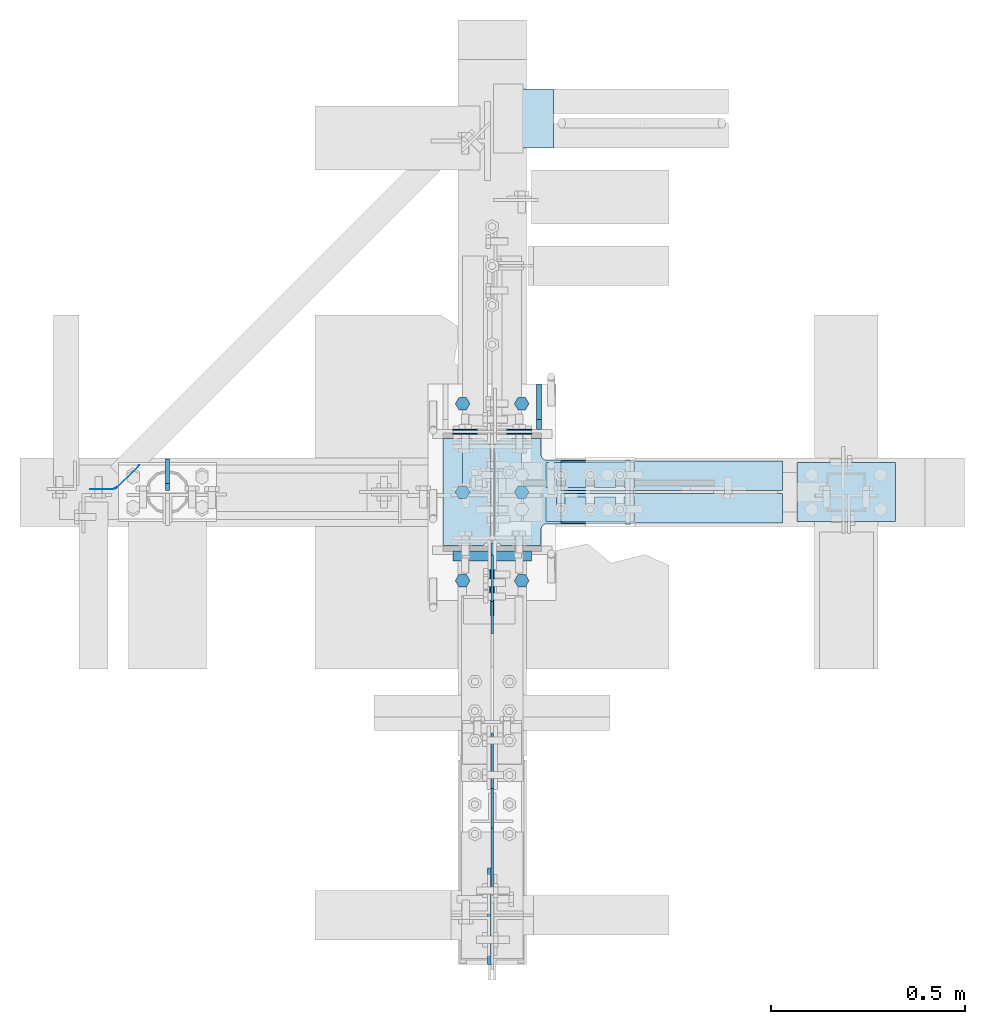
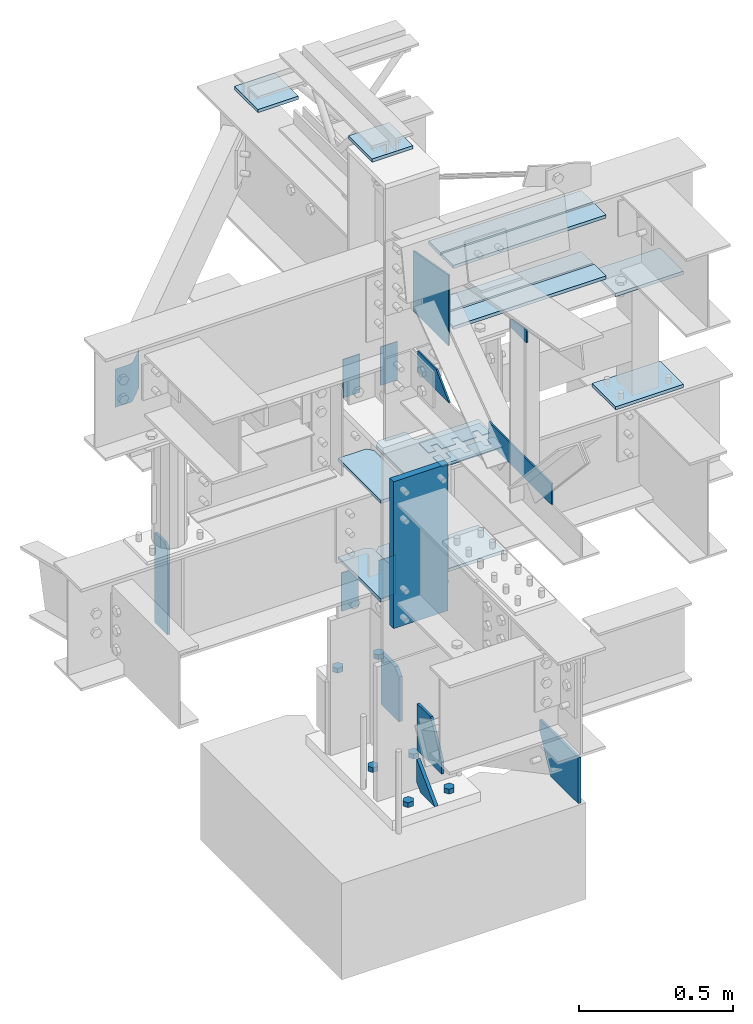
# Not in any storey, part 3 of 8: 35 plates, 23 elements without a shape of their own.
"""IFC2X3 building model written with IfcOpenShell, lengths in inches."""

from ifc_helpers import new_model, entity, si_unit, converted_unit, frame, origin_with_axes, place, context, project, spatial, extrude, faceted_brep, source, transform, mapped, material, type_object, type_shapes, element, aggregate, save


model = new_model("IFC2X3")

# Units and contexts
model_context = context("Model", 3, precision=1e-05, world=origin_with_axes())
ifc_project = project(units=[converted_unit("LENGTHUNIT", "INCH", entity("IfcLengthMeasure", 25.4), si_unit("LENGTHUNIT", "METRE", prefix="MILLI"), dimensions=[1, 0, 0, 0, 0, 0, 0]), si_unit("PLANEANGLEUNIT", "RADIAN"), si_unit("MASSUNIT", "GRAM", prefix="KILO"), si_unit("TIMEUNIT", "SECOND"), si_unit("AREAUNIT", "SQUARE_METRE"), si_unit("PRESSUREUNIT", "PASCAL"), si_unit("FORCEUNIT", "NEWTON"), si_unit("THERMODYNAMICTEMPERATUREUNIT", "DEGREE_CELSIUS")], contexts=[model_context])

# Site, building
site_placement = place(None, origin_with_axes())
site = spatial("IfcSite", under=ifc_project, at=site_placement, CompositionType="ELEMENT")
building_placement = place(site_placement, origin_with_axes())
building = spatial("IfcBuilding", under=site, at=building_placement, Name="Building", CompositionType="ELEMENT")

# Assembly, plate
assembly_1_placement = place(building_placement, frame((0.0, 0.0, 97.0), z_axis=(0.0, 0.0, -1.0), x_axis=(0.0, 1.0, 0.0)))
assembly_1 = element("IfcElementAssembly", 1, at=assembly_1_placement, inside=building, Name="M_40", PredefinedType="NOTDEFINED")
ifc_material = material()
plate_type_1 = type_object("IfcPlateType", Name="Plate (0-6x0-6)", PredefinedType="SHEET", material=ifc_material)
shared_shape_1 = source(origin_with_axes(), model_context, "Body", "Brep", [
    faceted_brep([(-0.25, 0.0, -6.0), (-0.25, -6.0, -6.0), (-0.25, -6.0, 0.0), (-0.25, 0.0, 0.0), (0.25, 0.0, 0.0), (0.25, -6.0, 0.0), (0.25, -6.0, -6.0), (0.25, 0.0, -6.0)], [[[0, 1, 2, 3]], [[4, 5, 6, 7]], [[7, 6, 1, 0]], [[6, 5, 2, 1]], [[5, 4, 3, 2]], [[4, 7, 0, 3]]]),
])
type_shapes(plate_type_1, [shared_shape_1])
plate_1_placement = place(assembly_1_placement, frame((6.25, -3.0, 2.24999999999999), z_axis=(0.0, -1.0, 0.0), x_axis=(0.0, 0.0, -1.0)))
plate_1 = element("IfcPlate", 2, at=plate_1_placement, type_object=plate_type_1, Name="p15", ObjectType="Member", context=model_context, shape_type="MappedRepresentation", body=[
    mapped(shared_shape_1, transform((0.0, 0.0, 0.0), scale=1.0)),
])
aggregate(assembly_1, [plate_1])

assembly_2_placement = place(building_placement, frame((0.0, 38.0, 82.5), z_axis=(0.0, 0.0, -1.0), x_axis=(1.0, 0.0, 0.0)))
assembly_2 = element("IfcElementAssembly", 3, at=assembly_2_placement, inside=building, Name="M_41", PredefinedType="NOTDEFINED")
plate_2_placement = place(assembly_2_placement, frame((6.25, -3.0, 2.24999999999999), z_axis=(0.0, -1.0, 0.0), x_axis=(0.0, 0.0, -1.0)))
plate_2 = element("IfcPlate", 4, at=plate_2_placement, type_object=plate_type_1, Name="p34", ObjectType="Member", context=model_context, shape_type="MappedRepresentation", body=[
    mapped(shared_shape_1, transform((0.0, 0.0, 0.0), scale=1.0)),
])
aggregate(assembly_2, [plate_2])

assembly_3_placement = place(building_placement, frame((1.5, 5.86499977111816, 54.75), z_axis=(-1.0, 0.0, 0.0), x_axis=(0.0, -1.0, 0.0)))
assembly_3 = element("IfcElementAssembly", 5, at=assembly_3_placement, inside=building, Name="1-4", PredefinedType="NOTDEFINED")
plate_type_2 = type_object("IfcPlateType", Name="Plate (2 1/2x0-6)", PredefinedType="SHEET", material=ifc_material)
shared_shape_2 = source(origin_with_axes(), model_context, "Body", "Brep", [
    faceted_brep([(-0.0625, 0.0, -2.5), (-0.0625, -6.0, -2.5), (-0.0625, -6.0, 0.0), (-0.0625, 0.0, 0.0), (0.0625, 0.0, 0.0), (0.0625, -6.0, 0.0), (0.0625, -6.0, -2.5), (0.0625, 0.0, -2.5)], [[[0, 1, 2, 3]], [[4, 5, 6, 7]], [[7, 6, 1, 0]], [[6, 5, 2, 1]], [[5, 4, 3, 2]], [[4, 7, 0, 3]]]),
])
type_shapes(plate_type_2, [shared_shape_2])
plate_3_placement = place(assembly_3_placement, frame((-0.0625, 0.0, 0.0), z_axis=(0.0, 0.0, 1.0), x_axis=(-1.0, 0.0, 0.0)))
plate_3 = element("IfcPlate", 6, at=plate_3_placement, type_object=plate_type_2, Name="p53", ObjectType="Member", context=model_context, shape_type="MappedRepresentation", body=[
    mapped(shared_shape_2, transform((0.0, 0.0, 0.0), scale=1.0)),
])
aggregate(assembly_3, [plate_3])

assembly_4_placement = place(building_placement, frame((-4.0, 5.86499977111816, 54.75), z_axis=(-1.0, 0.0, 0.0), x_axis=(0.0, -1.0, 0.0)))
assembly_4 = element("IfcElementAssembly", 7, at=assembly_4_placement, inside=building, Name="1-4", PredefinedType="NOTDEFINED")
plate_4_placement = place(assembly_4_placement, frame((-0.0625, 0.0, 0.0), z_axis=(0.0, 0.0, 1.0), x_axis=(-1.0, 0.0, 0.0)))
plate_4 = element("IfcPlate", 8, at=plate_4_placement, type_object=plate_type_2, Name="p53", ObjectType="Member", context=model_context, shape_type="MappedRepresentation", body=[
    mapped(shared_shape_2, transform((0.0, 0.0, 0.0), scale=1.0)),
])
aggregate(assembly_4, [plate_4])

assembly_5_placement = place(building_placement, frame((1.5, 6.28000068664551, 21.25), z_axis=(-1.0, 0.0, 0.0), x_axis=(0.0, -1.0, 0.0)))
assembly_5 = element("IfcElementAssembly", 9, at=assembly_5_placement, inside=building, Name="1-4", PredefinedType="NOTDEFINED")
plate_5_placement = place(assembly_5_placement, frame((-0.0625, 0.0, 0.0), z_axis=(0.0, 0.0, 1.0), x_axis=(-1.0, 0.0, 0.0)))
plate_5 = element("IfcPlate", 10, at=plate_5_placement, type_object=plate_type_2, Name="p53", ObjectType="Member", context=model_context, shape_type="MappedRepresentation", body=[
    mapped(shared_shape_2, transform((0.0, 0.0, 0.0), scale=1.0)),
])
aggregate(assembly_5, [plate_5])

assembly_6_placement = place(building_placement, frame((-4.0, 6.28000068664551, 21.25), z_axis=(-1.0, 0.0, 0.0), x_axis=(0.0, -1.0, 0.0)))
assembly_6 = element("IfcElementAssembly", 11, at=assembly_6_placement, inside=building, Name="1-4", PredefinedType="NOTDEFINED")
plate_6_placement = place(assembly_6_placement, frame((-0.0625, 0.0, 0.0), z_axis=(0.0, 0.0, 1.0), x_axis=(-1.0, 0.0, 0.0)))
plate_6 = element("IfcPlate", 12, at=plate_6_placement, type_object=plate_type_2, Name="p53", ObjectType="Member", context=model_context, shape_type="MappedRepresentation", body=[
    mapped(shared_shape_2, transform((0.0, 0.0, 0.0), scale=1.0)),
])
aggregate(assembly_6, [plate_6])

assembly_7_placement = place(building_placement, frame((3.0, 0.0, -22.6679382324219), z_axis=(0.0, -1.0, 0.0), x_axis=(0.0, 0.0, 1.0)))
assembly_7 = element("IfcElementAssembly", 13, at=assembly_7_placement, inside=building, Name="M_36", PredefinedType="NOTDEFINED")
plate_type_3 = type_object("IfcPlateType", Name="Plate (Complex)", PredefinedType="SHEET", material=ifc_material)
shared_shape_3 = source(origin_with_axes(), model_context, "Body", "Brep", [
    faceted_brep([(-0.375, 0.0, -1.125), (-0.375, -0.625, -1.5), (-0.375, -1.25, -1.125), (-0.375, -1.25, -0.375), (-0.375, -0.625, 0.0), (-0.375, 0.0, -0.375), (0.375, 0.0, -0.375), (0.375, -0.625, 0.0), (0.375, -1.25, -0.375), (0.375, -1.25, -1.125), (0.375, -0.625, -1.5), (0.375, 0.0, -1.125)], [[[0, 1, 2, 3, 4, 5]], [[6, 7, 8, 9, 10, 11]], [[11, 10, 1, 0]], [[10, 9, 2, 1]], [[9, 8, 3, 2]], [[8, 7, 4, 3]], [[7, 6, 5, 4]], [[6, 11, 0, 5]]]),
])
type_shapes(plate_type_3, [shared_shape_3])
plate_7_placement = place(assembly_7_placement, frame((23.1679382324209, 0.75, -0.625), z_axis=(0.0, 1.0, 0.0), x_axis=(1.0, 0.0, 0.0)))
plate_7 = element("IfcPlate", 14, at=plate_7_placement, type_object=plate_type_3, Name="p55", ObjectType="Member", context=model_context, shape_type="MappedRepresentation", body=[
    mapped(shared_shape_3, transform((0.0, 0.0, 0.0), scale=1.0)),
])
aggregate(assembly_7, [plate_7])

assembly_8_placement = place(building_placement, frame((3.0, -9.0, -22.6679382324219), z_axis=(0.0, -1.0, 0.0), x_axis=(0.0, 0.0, 1.0)))
assembly_8 = element("IfcElementAssembly", 15, at=assembly_8_placement, inside=building, Name="M_36", PredefinedType="NOTDEFINED")
plate_8_placement = place(assembly_8_placement, frame((23.1679382324209, 0.75, -0.625), z_axis=(0.0, 1.0, 0.0), x_axis=(1.0, 0.0, 0.0)))
plate_8 = element("IfcPlate", 16, at=plate_8_placement, type_object=plate_type_3, Name="p55", ObjectType="Member", context=model_context, shape_type="MappedRepresentation", body=[
    mapped(shared_shape_3, transform((0.0, 0.0, 0.0), scale=1.0)),
])
aggregate(assembly_8, [plate_8])

assembly_9_placement = place(building_placement, frame((3.0, 9.0, -22.6679382324219), z_axis=(0.0, -1.0, 0.0), x_axis=(0.0, 0.0, 1.0)))
assembly_9 = element("IfcElementAssembly", 17, at=assembly_9_placement, inside=building, Name="M_48", PredefinedType="NOTDEFINED")
plate_9_placement = place(assembly_9_placement, frame((33.1679382324209, 0.75, -0.625), z_axis=(0.0, 1.0, 0.0), x_axis=(1.0, 0.0, 0.0)))
plate_9 = element("IfcPlate", 18, at=plate_9_placement, type_object=plate_type_3, Name="p55", ObjectType="Member", context=model_context, shape_type="MappedRepresentation", body=[
    mapped(shared_shape_3, transform((0.0, 0.0, 0.0), scale=1.0)),
])
aggregate(assembly_9, [plate_9])

assembly_10_placement = place(building_placement, frame((-3.0, 0.0, -22.6679382324219), z_axis=(0.0, -1.0, 0.0), x_axis=(0.0, 0.0, 1.0)))
assembly_10 = element("IfcElementAssembly", 19, at=assembly_10_placement, inside=building, Name="M_35", PredefinedType="NOTDEFINED")
plate_10_placement = place(assembly_10_placement, frame((23.1679382324209, 0.75, -0.625), z_axis=(0.0, 1.0, 0.0), x_axis=(1.0, 0.0, 0.0)))
plate_10 = element("IfcPlate", 20, at=plate_10_placement, type_object=plate_type_3, Name="p55", ObjectType="Member", context=model_context, shape_type="MappedRepresentation", body=[
    mapped(shared_shape_3, transform((0.0, 0.0, 0.0), scale=1.0)),
])
aggregate(assembly_10, [plate_10])

assembly_11_placement = place(building_placement, frame((-3.0, -9.0, -22.6679382324219), z_axis=(0.0, -1.0, 0.0), x_axis=(0.0, 0.0, 1.0)))
assembly_11 = element("IfcElementAssembly", 21, at=assembly_11_placement, inside=building, Name="M_35", PredefinedType="NOTDEFINED")
plate_11_placement = place(assembly_11_placement, frame((23.1679382324209, 0.75, -0.625), z_axis=(0.0, 1.0, 0.0), x_axis=(1.0, 0.0, 0.0)))
plate_11 = element("IfcPlate", 22, at=plate_11_placement, type_object=plate_type_3, Name="p55", ObjectType="Member", context=model_context, shape_type="MappedRepresentation", body=[
    mapped(shared_shape_3, transform((0.0, 0.0, 0.0), scale=1.0)),
])
aggregate(assembly_11, [plate_11])

assembly_12_placement = place(building_placement, frame((-3.0, 9.0, -22.6679382324219), z_axis=(0.0, -1.0, 0.0), x_axis=(0.0, 0.0, 1.0)))
assembly_12 = element("IfcElementAssembly", 23, at=assembly_12_placement, inside=building, Name="M_50", PredefinedType="NOTDEFINED")
plate_12_placement = place(assembly_12_placement, frame((33.1679382324209, 0.75, -0.625), z_axis=(0.0, 1.0, 0.0), x_axis=(1.0, 0.0, 0.0)))
plate_12 = element("IfcPlate", 24, at=plate_12_placement, type_object=plate_type_3, Name="p55", ObjectType="Member", context=model_context, shape_type="MappedRepresentation", body=[
    mapped(shared_shape_3, transform((0.0, 0.0, 0.0), scale=1.0)),
])
aggregate(assembly_12, [plate_12])

assembly_13_placement = place(building_placement, frame((5.48500061035156, 3.0, 46.0), z_axis=(-1.0, 0.0, 0.0), x_axis=(0.0, 0.0, 1.0)))
assembly_13 = element("IfcElementAssembly", 25, at=assembly_13_placement, inside=building, Name="1-5", PredefinedType="NOTDEFINED")
plate_type_4 = type_object("IfcPlateType", Name="Plate (Complex)", PredefinedType="SHEET", material=ifc_material)
shared_shape_4 = source(origin_with_axes(), model_context, "Body", "Brep", [
    faceted_brep([(-0.0625, -1.25, -1.0625), (-0.0625, -2.5, -1.0625), (-0.0625, -2.5, 0.0), (-0.0625, 0.0, 0.0), (-0.0625, 0.0, -9.0), (-0.0625, -2.5, -9.0), (-0.0625, -2.5, -7.938), (-0.0625, -1.25, -7.938), (-0.0625, -1.25, -7.063), (-0.0625, -2.5, -7.063), (-0.0625, -2.5, -4.9375), (-0.0625, -1.25, -4.9375), (-0.0625, -1.25, -4.0625), (-0.0625, -2.5, -4.0625), (-0.0625, -2.5, -1.9375), (-0.0625, -1.25, -1.9375), (0.0625, -1.25, -1.9375), (0.0625, -2.5, -1.9375), (0.0625, -2.5, -4.0625), (0.0625, -1.25, -4.0625), (0.0625, -1.25, -4.9375), (0.0625, -2.5, -4.9375), (0.0625, -2.5, -7.063), (0.0625, -1.25, -7.063), (0.0625, -1.25, -7.938), (0.0625, -2.5, -7.938), (0.0625, -2.5, -9.0), (0.0625, 0.0, -9.0), (0.0625, 0.0, 0.0), (0.0625, -2.5, 0.0), (0.0625, -2.5, -1.0625), (0.0625, -1.25, -1.0625)], [[[0, 1, 2, 3, 4, 5, 6, 7, 8, 9, 10, 11, 12, 13, 14, 15]], [[16, 17, 18, 19, 20, 21, 22, 23, 24, 25, 26, 27, 28, 29, 30, 31]], [[31, 30, 1, 0]], [[30, 29, 2, 1]], [[29, 28, 3, 2]], [[28, 27, 4, 3]], [[27, 26, 5, 4]], [[26, 25, 6, 5]], [[25, 24, 7, 6]], [[24, 23, 8, 7]], [[23, 22, 9, 8]], [[22, 21, 10, 9]], [[21, 20, 11, 10]], [[20, 19, 12, 11]], [[19, 18, 13, 12]], [[18, 17, 14, 13]], [[17, 16, 15, 14]], [[16, 31, 0, 15]]]),
])
type_shapes(plate_type_4, [shared_shape_4])
plate_13_placement = place(assembly_13_placement, frame((0.0624999999999858, 0.0, 0.0), z_axis=(0.0, 0.0, 1.0), x_axis=(1.0, 0.0, 0.0)))
plate_13 = element("IfcPlate", 26, at=plate_13_placement, type_object=plate_type_4, Name="p56", ObjectType="Member", context=model_context, shape_type="MappedRepresentation", body=[
    mapped(shared_shape_4, transform((0.0, 0.0, 0.0), scale=1.0)),
])
aggregate(assembly_13, [plate_13])

assembly_14_placement = place(building_placement, frame((5.48500061035156, -3.0, 46.0), z_axis=(-1.0, 0.0, 0.0), x_axis=(0.0, 0.0, 1.0)))
assembly_14 = element("IfcElementAssembly", 27, at=assembly_14_placement, inside=building, Name="1-5", PredefinedType="NOTDEFINED")
plate_14_placement = place(assembly_14_placement, frame((0.0624999999999858, 0.0, -9.0), z_axis=(0.0, 0.0, -1.0), x_axis=(1.0, 0.0, 0.0)))
plate_14 = element("IfcPlate", 28, at=plate_14_placement, type_object=plate_type_4, Name="p56", ObjectType="Member", context=model_context, shape_type="MappedRepresentation", body=[
    mapped(shared_shape_4, transform((0.0, 0.0, 0.0), scale=1.0)),
])
aggregate(assembly_14, [plate_14])

# Assembly, plates
assembly_15_placement = place(building_placement, frame((0.0, 0.0, -1.5), z_axis=(0.0, -1.0, 0.0), x_axis=(0.0, 0.0, 1.0)))
assembly_15 = element("IfcElementAssembly", 29, at=assembly_15_placement, inside=building, Name="1-1", PredefinedType="NOTDEFINED")
plate_type_5 = type_object("IfcPlateType", Name="Plate (Complex)", PredefinedType="SHEET", material=ifc_material)
shared_shape_5 = source(origin_with_axes(), model_context, "Body", "Brep", [
    faceted_brep([(-0.25, 0.0, -8.0), (-0.25, -3.625, -8.0), (-0.25, -4.625, -7.0), (-0.25, -4.625, 0.0), (-0.25, 0.0, 0.0), (0.25, 0.0, 0.0), (0.25, -4.625, 0.0), (0.25, -4.625, -7.0), (0.25, -3.625, -8.0), (0.25, 0.0, -8.0)], [[[0, 1, 2, 3, 4]], [[5, 6, 7, 8, 9]], [[9, 8, 1, 0]], [[8, 7, 2, 1]], [[7, 6, 3, 2]], [[6, 5, 4, 3]], [[5, 9, 0, 4]]]),
])
type_shapes(plate_type_5, [shared_shape_5])
plate_15_placement = place(assembly_15_placement, frame((2.5, -4.75, -10.9999995231628), z_axis=(-1.0, 0.0, 0.0), x_axis=(0.0, 1.0, 0.0)))
plate_15 = element("IfcPlate", 30, at=plate_15_placement, type_object=plate_type_5, Name="p21", ObjectType="Column", context=model_context, shape_type="MappedRepresentation", body=[
    mapped(shared_shape_5, transform((0.0, 0.0, 0.0), scale=1.0)),
])
plate_type_6 = type_object("IfcPlateType", Name="Plate (Complex)", PredefinedType="SHEET", material=ifc_material)
shared_shape_6 = source(origin_with_axes(), model_context, "Body", "Brep", [
    faceted_brep([(-0.1875, -6.355, -5.002), (-0.1875, -9.7925, -5.002), (-0.1875, -12.605, 0.31), (-0.1875, -12.605, 2.248), (-0.1875, -6.355, 2.248), (0.1875, -6.355, 2.248), (0.1875, -12.605, 2.248), (0.1875, -12.605, 0.31), (0.1875, -9.7925, -5.002), (0.1875, -6.355, -5.002)], [[[0, 1, 2, 3, 4]], [[5, 6, 7, 8, 9]], [[9, 8, 1, 0]], [[8, 7, 2, 1]], [[7, 6, 3, 2]], [[6, 5, 4, 3]], [[5, 9, 0, 4]]]),
])
type_shapes(plate_type_6, [shared_shape_6])
plate_16_placement = place(assembly_15_placement, frame((9.74793626708778, 0.0, 1.38770374746855e-07), z_axis=(-1.0, 0.0, 0.0), x_axis=(0.0, 1.0, 0.0)))
plate_16 = element("IfcPlate", 31, at=plate_16_placement, type_object=plate_type_6, Name="p59", ObjectType="Column", context=model_context, shape_type="MappedRepresentation", body=[
    mapped(shared_shape_6, transform((0.0, 0.0, 0.0), scale=1.0)),
])
plate_type_7 = type_object("IfcPlateType", Name="Plate (Complex)", PredefinedType="SHEET", material=ifc_material)
shared_shape_7 = source(origin_with_axes(), model_context, "Body", "Brep", [
    faceted_brep([(-0.25, -4.625, -4.625), (-0.25, -4.625, -1.0), (-0.25, -3.625, 0.0), (-0.25, 0.0, 0.0), (0.25, 0.0, 0.0), (0.25, -3.625, 0.0), (0.25, -4.625, -1.0), (0.25, -4.625, -4.625)], [[[0, 1, 2, 3]], [[4, 5, 6, 7]], [[7, 6, 1, 0]], [[6, 5, 2, 1]], [[5, 4, 3, 2]], [[4, 7, 0, 3]]]),
])
type_shapes(plate_type_7, [shared_shape_7])
plate_17_placement = place(assembly_15_placement, frame((6.125, 0.0, 6.375), z_axis=(0.0, 0.0, -1.0), x_axis=(0.0, 1.0, 0.0)))
plate_17 = element("IfcPlate", 32, at=plate_17_placement, type_object=plate_type_7, Name="p41", ObjectType="Column", context=model_context, shape_type="MappedRepresentation", body=[
    mapped(shared_shape_7, transform((0.0, 0.0, 0.0), scale=1.0)),
])
aggregate(assembly_15, [plate_16, plate_17, plate_15])

assembly_16_placement = place(building_placement, frame((0.0, 0.0, 21.0), z_axis=(0.0, -1.0, 0.0), x_axis=(0.0, 0.0, 1.0)))
assembly_16 = element("IfcElementAssembly", 33, at=assembly_16_placement, inside=building, Name="1-2", PredefinedType="NOTDEFINED")
plate_type_8 = type_object("IfcPlateType", Name="Plate (Complex)", PredefinedType="SHEET", material=ifc_material)
shared_shape_8 = source(origin_with_axes(), model_context, "Body", "Brep", [
    faceted_brep([(-0.25, 5.3925, -4.8125), (-0.25, 3.705, -4.8125), (-0.25, 3.51366, -4.851), (-0.25, 3.35145, -4.959), (-0.25, 3.24306, -5.121), (-0.25, 3.205, -5.3125), (-0.25, 3.205, -14.25), (-0.25, -3.295, -14.25), (-0.25, -3.295, -5.3125), (-0.25, -3.33306, -5.121), (-0.25, -3.44145, -4.959), (-0.25, -3.60366, -4.851), (-0.25, -3.795, -4.8125), (-0.25, -5.4825, -4.8125), (-0.25, -5.4825, -0.75), (-0.25, -4.7325, 0.0), (-0.25, 4.6425, 0.0), (-0.25, 5.3925, -0.75), (0.25, 5.3925, -0.75), (0.25, 4.6425, 0.0), (0.25, -4.7325, 0.0), (0.25, -5.4825, -0.75), (0.25, -5.4825, -4.8125), (0.25, -3.795, -4.8125), (0.25, -3.60366, -4.851), (0.25, -3.44145, -4.959), (0.25, -3.33306, -5.121), (0.25, -3.295, -5.3125), (0.25, -3.295, -14.25), (0.25, 3.205, -14.25), (0.25, 3.205, -5.3125), (0.25, 3.24306, -5.121), (0.25, 3.35145, -4.959), (0.25, 3.51366, -4.851), (0.25, 3.705, -4.8125), (0.25, 5.3925, -4.8125)], [[[0, 1, 2, 3, 4, 5, 6, 7, 8, 9, 10, 11, 12, 13, 14, 15, 16, 17]], [[18, 19, 20, 21, 22, 23, 24, 25, 26, 27, 28, 29, 30, 31, 32, 33, 34, 35]], [[35, 34, 1, 0]], [[34, 33, 2, 1]], [[33, 32, 3, 2]], [[32, 31, 4, 3]], [[31, 30, 5, 4]], [[30, 29, 6, 5]], [[29, 28, 7, 6]], [[28, 27, 8, 7]], [[27, 26, 9, 8]], [[26, 25, 10, 9]], [[25, 24, 11, 10]], [[24, 23, 12, 11]], [[23, 22, 13, 12]], [[22, 21, 14, 13]], [[21, 20, 15, 14]], [[20, 19, 16, 15]], [[19, 18, 17, 16]], [[18, 35, 0, 17]]]),
])
type_shapes(plate_type_8, [shared_shape_8])
plate_18_placement = place(assembly_16_placement, frame((8.875, -0.172499999403954, -0.0625000184680626), z_axis=(0.0, 1.0, 0.0), x_axis=(1.0, 0.0, 0.0)))
plate_18 = element("IfcPlate", 34, at=plate_18_placement, type_object=plate_type_8, Name="p17", ObjectType="Column", context=model_context, shape_type="MappedRepresentation", body=[
    mapped(shared_shape_8, transform((0.0, 0.0, 0.0), scale=1.0)),
])
plate_19_placement = place(assembly_16_placement, frame((25.375, -0.172499999403953, -0.0625000184680629), z_axis=(0.0, 1.0, 0.0), x_axis=(1.0, 0.0, 0.0)))
plate_19 = element("IfcPlate", 35, at=plate_19_placement, type_object=plate_type_8, Name="p17", ObjectType="Column", context=model_context, shape_type="MappedRepresentation", body=[
    mapped(shared_shape_8, transform((0.0, 0.0, 0.0), scale=1.0)),
])
plate_type_9 = type_object("IfcPlateType", Name="Plate (Complex)", PredefinedType="SHEET", material=ifc_material)
shared_shape_9 = source(origin_with_axes(), model_context, "Body", "Brep", [
    faceted_brep([(-0.25, 5.4375, -4.8125), (-0.25, -5.4375, -4.8125), (-0.25, -5.4375, -0.75), (-0.25, -4.6875, 0.0), (-0.25, 4.6875, 0.0), (-0.25, 5.4375, -0.75), (0.25, 5.4375, -0.75), (0.25, 4.6875, 0.0), (0.25, -4.6875, 0.0), (0.25, -5.4375, -0.75), (0.25, -5.4375, -4.8125), (0.25, 5.4375, -4.8125)], [[[0, 1, 2, 3, 4, 5]], [[6, 7, 8, 9, 10, 11]], [[11, 10, 1, 0]], [[10, 9, 2, 1]], [[9, 8, 3, 2]], [[8, 7, 4, 3]], [[7, 6, 5, 4]], [[6, 11, 0, 5]]]),
])
type_shapes(plate_type_9, [shared_shape_9])
plate_20_placement = place(assembly_16_placement, frame((24.75, 0.172500014305114, 1.8468062926954e-08), z_axis=(0.0, -1.0, 0.0), x_axis=(1.0, 0.0, 0.0)))
plate_20 = element("IfcPlate", 36, at=plate_20_placement, type_object=plate_type_9, Name="p18", ObjectType="Column", context=model_context, shape_type="MappedRepresentation", body=[
    mapped(shared_shape_9, transform((0.0, 0.0, 0.0), scale=1.0)),
])
plate_21_placement = place(assembly_16_placement, frame((9.375, 0.172500014305114, 1.8468062926954e-08), z_axis=(0.0, -1.0, 0.0), x_axis=(1.0, 0.0, 0.0)))
plate_21 = element("IfcPlate", 37, at=plate_21_placement, type_object=plate_type_9, Name="p18", ObjectType="Column", context=model_context, shape_type="MappedRepresentation", body=[
    mapped(shared_shape_9, transform((0.0, 0.0, 0.0), scale=1.0)),
])
aggregate(assembly_16, [plate_18, plate_20, plate_21, plate_19])

# Assembly, plate
assembly_17_placement = place(building_placement, frame((0.0, 0.0, 46.0), z_axis=(0.0, 0.0, 1.0), x_axis=(-1.0, 0.0, 0.0)))
assembly_17 = element("IfcElementAssembly", 38, at=assembly_17_placement, inside=building, Name="2-4", PredefinedType="NOTDEFINED")
plate_type_10 = type_object("IfcPlateType", Name="Plate (Complex)", PredefinedType="SHEET", material=ifc_material)
shared_shape_10 = source(origin_with_axes(), model_context, "Body", "Brep", [
    faceted_brep([(-0.1875, 0.0, -14.0), (-0.1875, -3.25, -14.0), (-0.1875, -3.25, 0.0), (-0.1875, -0.75, 0.0), (-0.1875, 0.0, -0.75), (0.1875, 0.0, -0.75), (0.1875, -0.75, 0.0), (0.1875, -3.25, 0.0), (0.1875, -3.25, -14.0), (0.1875, 0.0, -14.0)], [[[0, 1, 2, 3, 4]], [[5, 6, 7, 8, 9]], [[9, 8, 1, 0]], [[8, 7, 2, 1]], [[7, 6, 3, 2]], [[6, 5, 4, 3]], [[5, 9, 0, 4]]]),
])
type_shapes(plate_type_10, [shared_shape_10])
plate_22_placement = place(assembly_17_placement, frame((33.0, -0.14750000834465, -0.492500007152557), z_axis=(0.0, 0.0, 1.0), x_axis=(1.0, 0.0, 0.0)))
plate_22 = element("IfcPlate", 39, at=plate_22_placement, type_object=plate_type_10, Name="p4", ObjectType="Beam", context=model_context, shape_type="MappedRepresentation", body=[
    mapped(shared_shape_10, transform((0.0, 0.0, 0.0), scale=1.0)),
])
aggregate(assembly_17, [plate_22])

assembly_18_placement = place(building_placement, frame((0.0, 0.0, 46.0), z_axis=(0.0, 0.0, 1.0), x_axis=(0.0, -1.0, 0.0)))
assembly_18 = element("IfcElementAssembly", 40, at=assembly_18_placement, inside=building, Name="2-1", PredefinedType="NOTDEFINED")
plate_type_11 = type_object("IfcPlateType", Name="Plate (1-10 7/8x0-8)", PredefinedType="SHEET", material=ifc_material)
shared_shape_11 = source(origin_with_axes(), model_context, "Body", "Brep", [
    faceted_brep([(-0.5, 4.0, -22.875), (-0.5, -4.0, -22.875), (-0.5, -4.0, 0.0), (-0.5, 4.0, 0.0), (0.5, 4.0, 0.0), (0.5, -4.0, 0.0), (0.5, -4.0, -22.875), (0.5, 4.0, -22.875)], [[[0, 1, 2, 3]], [[4, 5, 6, 7]], [[7, 6, 1, 0]], [[6, 5, 2, 1]], [[5, 4, 3, 2]], [[4, 7, 0, 3]]]),
])
type_shapes(plate_type_11, [shared_shape_11])
plate_23_placement = place(assembly_18_placement, frame((6.5, 0.0, 3.5), z_axis=(0.0, 0.0, 1.0), x_axis=(-1.0, 0.0, 0.0)))
plate_23 = element("IfcPlate", 41, at=plate_23_placement, type_object=plate_type_11, Name="p24", ObjectType="Beam", context=model_context, shape_type="MappedRepresentation", body=[
    mapped(shared_shape_11, transform((0.0, 0.0, 0.0), scale=1.0)),
])
aggregate(assembly_18, [plate_23])

assembly_19_placement = place(building_placement, frame((0.0, -27.0, 46.0), z_axis=(0.0, 0.0, 1.0), x_axis=(0.0, -1.0, 0.0)))
assembly_19 = element("IfcElementAssembly", 42, at=assembly_19_placement, inside=building, Name="2-2", PredefinedType="NOTDEFINED")
plate_type_12 = type_object("IfcPlateType", Name="Plate (Complex)", PredefinedType="SHEET", material=ifc_material)
shared_shape_12 = source(origin_with_axes(), model_context, "Body", "Brep", [
    faceted_brep([(-0.1875, 0.0, -9.8125), (-0.1875, -1.8125, -9.8125), (-0.1875, -7.125, -7.0), (-0.1875, -7.125, 0.0), (-0.1875, 0.0, 0.0), (0.1875, 0.0, 0.0), (0.1875, -7.125, 0.0), (0.1875, -7.125, -7.0), (0.1875, -1.8125, -9.8125), (0.1875, 0.0, -9.8125)], [[[0, 1, 2, 3, 4]], [[5, 6, 7, 8, 9]], [[9, 8, 1, 0]], [[8, 7, 2, 1]], [[7, 6, 3, 2]], [[6, 5, 4, 3]], [[5, 9, 0, 4]]]),
])
type_shapes(plate_type_12, [shared_shape_12])
plate_24_placement = place(assembly_19_placement, frame((20.999999265308, -0.302501678466797, -15.8600003826132), z_axis=(1.0, 0.0, 0.0), x_axis=(0.0, 1.0, 0.0)))
plate_24 = element("IfcPlate", 43, at=plate_24_placement, type_object=plate_type_12, Name="p6", ObjectType="Beam", context=model_context, shape_type="MappedRepresentation", body=[
    mapped(shared_shape_12, transform((0.0, 0.0, 0.0), scale=1.0)),
])
aggregate(assembly_19, [plate_24])

# Assembly, plates
assembly_20_placement = place(building_placement, frame((36.0, 0.0, 46.0), z_axis=(-1.0, 0.0, 0.0), x_axis=(0.0, 0.0, 1.0)))
assembly_20 = element("IfcElementAssembly", 44, at=assembly_20_placement, inside=building, Name="4-1", PredefinedType="NOTDEFINED")
plate_type_13 = type_object("IfcPlateType", Name="Plate (0-10x0-6)", PredefinedType="SHEET", material=ifc_material)
shared_shape_13 = source(origin_with_axes(), model_context, "Body", "Brep", [
    faceted_brep([(-0.25, 3.0, -5.0), (-0.25, -3.0, -5.0), (-0.25, -3.0, 5.0), (-0.25, 3.0, 5.0), (0.25, 3.0, 5.0), (0.25, -3.0, 5.0), (0.25, -3.0, -5.0), (0.25, 3.0, -5.0)], [[[0, 1, 2, 3]], [[4, 5, 6, 7]], [[7, 6, 1, 0]], [[6, 5, 2, 1]], [[5, 4, 3, 2]], [[4, 7, 0, 3]]]),
])
type_shapes(plate_type_13, [shared_shape_13])
plate_25_placement = place(assembly_20_placement, frame((0.25, 0.0, 0.0), z_axis=(0.0, 0.0, -1.0), x_axis=(1.0, 0.0, 0.0)))
plate_25 = element("IfcPlate", 45, at=plate_25_placement, type_object=plate_type_13, Name="p48", ObjectType="Column", context=model_context, shape_type="MappedRepresentation", body=[
    mapped(shared_shape_13, transform((0.0, 0.0, 0.0), scale=1.0)),
])
plate_26_placement = place(assembly_20_placement, frame((17.875, 0.0, 0.0), z_axis=(0.0, 0.0, -1.0), x_axis=(-1.0, 0.0, 0.0)))
plate_26 = element("IfcPlate", 46, at=plate_26_placement, type_object=plate_type_13, Name="p48", ObjectType="Column", context=model_context, shape_type="MappedRepresentation", body=[
    mapped(shared_shape_13, transform((0.0, 0.0, 0.0), scale=1.0)),
])
aggregate(assembly_20, [plate_25, plate_26])

# Assembly, plate
assembly_21_placement = place(building_placement, frame((-38.0, 0.0, 77.0), z_axis=(0.0, 0.0, 1.0), x_axis=(0.707106765732237, 0.707106796640858, 0.0)))
assembly_21 = element("IfcElementAssembly", 47, at=assembly_21_placement, inside=building, Name="3-12", PredefinedType="NOTDEFINED")
plate_type_14 = type_object("IfcPlateType", Name="BPL3/8x6-1/2", PredefinedType="USERDEFINED")
shared_shape_14 = source(origin_with_axes(), model_context, "Body", "SweptSolid", [
    extrude(entity("IfcCenterLineProfileDef", "AREA", None, entity("IfcPolyline", [entity("IfcCartesianPoint", [-3.5, 0.1875]), entity("IfcCartesianPoint", [-0.38832, 0.1875]), entity("IfcCartesianPoint", [-0.19421, 0.2131]), entity("IfcCartesianPoint", [-0.01333, 0.288]), entity("IfcCartesianPoint", [0.142, 0.4072]), entity("IfcCartesianPoint", [1.733, 1.9982])]), 0.375), frame((0.0, 0.0, 0.0), z_axis=(1.0, 0.0, 0.0), x_axis=(0.0, 1.0, 0.0)), (0.0, 0.0, 1.0), 6.0),
])
type_shapes(plate_type_14, [shared_shape_14])
plate_27_placement = place(assembly_21_placement, frame((-0.0454999499840696, 0.232999995350838, -1.5), z_axis=(0.0, 1.0, 0.0), x_axis=(0.0, 0.0, -1.0)))
plate_27 = element("IfcPlate", 48, at=plate_27_placement, type_object=plate_type_14, Name="bp6", ObjectType="Beam", context=model_context, shape_type="MappedRepresentation", body=[
    mapped(shared_shape_14, transform((0.0, 0.0, 0.0), scale=1.0)),
])
aggregate(assembly_21, [plate_27])

# Assembly, plates
assembly_22_placement = place(building_placement, frame((0.0, 0.0, 80.0), z_axis=(0.0, 0.0, 1.0), x_axis=(1.0, 0.0, 0.0)))
assembly_22 = element("IfcElementAssembly", 49, at=assembly_22_placement, inside=building, Name="2-8", PredefinedType="NOTDEFINED")
plate_type_15 = type_object("IfcPlateType", Name="Plate (1-10 1/2x0-3)", PredefinedType="SHEET", material=ifc_material)
shared_shape_15 = source(origin_with_axes(), model_context, "Body", "Brep", [
    faceted_brep([(-0.25, 0.0, -22.5), (-0.25, -3.0, -22.5), (-0.25, -3.0, 0.0), (-0.25, 0.0, 0.0), (0.25, 0.0, 0.0), (0.25, -3.0, 0.0), (0.25, -3.0, -22.5), (0.25, 0.0, -22.5)], [[[0, 1, 2, 3]], [[4, 5, 6, 7]], [[7, 6, 1, 0]], [[6, 5, 2, 1]], [[5, 4, 3, 2]], [[4, 7, 0, 3]]]),
])
type_shapes(plate_type_15, [shared_shape_15])
plate_28_placement = place(assembly_22_placement, frame((29.5, 0.147500008344651, -12.75), z_axis=(1.0, 0.0, 0.0), x_axis=(0.0, 0.0, 1.0)))
plate_28 = element("IfcPlate", 50, at=plate_28_placement, type_object=plate_type_15, Name="p23", ObjectType="Beam", context=model_context, shape_type="MappedRepresentation", body=[
    mapped(shared_shape_15, transform((0.0, 0.0, 0.0), scale=1.0)),
])
plate_29_placement = place(assembly_22_placement, frame((7.0, -0.14750000834465, -12.75), z_axis=(-1.0, 0.0, 0.0), x_axis=(0.0, 0.0, 1.0)))
plate_29 = element("IfcPlate", 51, at=plate_29_placement, type_object=plate_type_15, Name="p23", ObjectType="Beam", context=model_context, shape_type="MappedRepresentation", body=[
    mapped(shared_shape_15, transform((0.0, 0.0, 0.0), scale=1.0)),
])
plate_30_placement = place(assembly_22_placement, frame((29.5, 0.147500008344651, -3.25), z_axis=(1.0, 0.0, 0.0), x_axis=(0.0, 0.0, 1.0)))
plate_30 = element("IfcPlate", 52, at=plate_30_placement, type_object=plate_type_15, Name="p23", ObjectType="Beam", context=model_context, shape_type="MappedRepresentation", body=[
    mapped(shared_shape_15, transform((0.0, 0.0, 0.0), scale=1.0)),
])
plate_31_placement = place(assembly_22_placement, frame((7.0, -0.14750000834465, -3.25), z_axis=(-1.0, 0.0, 0.0), x_axis=(0.0, 0.0, 1.0)))
plate_31 = element("IfcPlate", 53, at=plate_31_placement, type_object=plate_type_15, Name="p23", ObjectType="Beam", context=model_context, shape_type="MappedRepresentation", body=[
    mapped(shared_shape_15, transform((0.0, 0.0, 0.0), scale=1.0)),
])
aggregate(assembly_22, [plate_28, plate_29, plate_30, plate_31])

assembly_23_placement = place(building_placement, frame((0.0, -47.9999999999999, 94.0), z_axis=(0.0, 0.17437043319647, 0.984680126755321), x_axis=(0.0, 0.98468012675532, -0.17437043319647)))
assembly_23 = element("IfcElementAssembly", 54, at=assembly_23_placement, inside=building, Name="4-8", PredefinedType="NOTDEFINED")
plate_type_16 = type_object("IfcPlateType", Name="Plate (Complex)", PredefinedType="SHEET", material=ifc_material)
shared_shape_16 = source(origin_with_axes(), model_context, "Body", "Brep", [
    faceted_brep([(-0.125, 0.0, -4.75), (-0.125, -3.25, -8.0), (-0.125, -3.25, 0.0), (-0.125, 0.0, 0.0), (0.125, 0.0, 0.0), (0.125, -3.25, 0.0), (0.125, -3.25, -8.0), (0.125, 0.0, -4.75)], [[[0, 1, 2, 3]], [[4, 5, 6, 7]], [[7, 6, 1, 0]], [[6, 5, 2, 1]], [[5, 4, 3, 2]], [[4, 7, 0, 3]]]),
])
type_shapes(plate_type_16, [shared_shape_16])
plate_32_placement = place(assembly_23_placement, frame((45.4978375101134, -0.00999999791383743, -18.2130441975408), z_axis=(0.98468012675532, 0.0, 0.17437043319647), x_axis=(0.0, 1.0, 0.0)))
plate_32 = element("IfcPlate", 55, at=plate_32_placement, type_object=plate_type_16, Name="p50", ObjectType="Beam", context=model_context, shape_type="MappedRepresentation", body=[
    mapped(shared_shape_16, transform((0.0, 0.0, 0.0), scale=1.0)),
])
plate_type_17 = type_object("IfcPlateType", Name="Plate (Complex)", PredefinedType="SHEET", material=ifc_material)
shared_shape_17 = source(origin_with_axes(), model_context, "Body", "Brep", [
    faceted_brep([(-0.125, 1e-05, -4.0), (-0.125, -2.0, -4.0), (-0.125, -2.0, 0.0), (-0.125, -0.70833, 0.0), (0.125, -0.70833, 0.0), (0.125, -2.0, 0.0), (0.125, -2.0, -4.0), (0.125, 1e-05, -4.0)], [[[0, 1, 2, 3]], [[4, 5, 6, 7]], [[7, 6, 1, 0]], [[6, 5, 2, 1]], [[5, 4, 3, 2]], [[4, 7, 0, 3]]]),
])
type_shapes(plate_type_17, [shared_shape_17])
plate_33_placement = place(assembly_23_placement, frame((18.5967003567752, 0.0, -2.58001890383456), z_axis=(0.98468012675532, 0.0, 0.17437043319647), x_axis=(0.0, 1.0, 0.0)))
plate_33 = element("IfcPlate", 56, at=plate_33_placement, type_object=plate_type_17, Name="p60", ObjectType="Beam", context=model_context, shape_type="MappedRepresentation", body=[
    mapped(shared_shape_17, transform((0.0, 0.0, 0.0), scale=1.0)),
])
plate_type_18 = type_object("IfcPlateType", Name="Plate (1-4x3 1/4)", PredefinedType="SHEET", material=ifc_material)
shared_shape_18 = source(origin_with_axes(), model_context, "Body", "Brep", [
    faceted_brep([(-0.125, 0.0, -16.0), (-0.125, -3.25, -16.0), (-0.125, -3.25, 0.0), (-0.125, 0.0, 0.0), (0.125, 0.0, 0.0), (0.125, -3.25, 0.0), (0.125, -3.25, -16.0), (0.125, 0.0, -16.0)], [[[0, 1, 2, 3]], [[4, 5, 6, 7]], [[7, 6, 1, 0]], [[6, 5, 2, 1]], [[5, 4, 3, 2]], [[4, 7, 0, 3]]]),
])
type_shapes(plate_type_18, [shared_shape_18])
plate_34_placement = place(assembly_23_placement, frame((27.6426746614327, 0.0, -21.3748958447119), z_axis=(0.98468012675532, 0.0, 0.17437043319647), x_axis=(0.0, 1.0, 0.0)))
plate_34 = element("IfcPlate", 57, at=plate_34_placement, type_object=plate_type_18, Name="p28", ObjectType="Beam", context=model_context, shape_type="MappedRepresentation", body=[
    mapped(shared_shape_18, transform((0.0, 0.0, 0.0), scale=1.0)),
])
plate_type_19 = type_object("IfcPlateType", Name="Plate (Complex)", PredefinedType="SHEET", material=ifc_material)
shared_shape_19 = source(origin_with_axes(), model_context, "Body", "Brep", [
    faceted_brep([(-0.125, 0.0, -9.39), (-0.125, -9.0, -11.015), (-0.125, -9.0, 0.0), (-0.125, 0.0, 0.0), (0.125, 0.0, 0.0), (0.125, -9.0, 0.0), (0.125, -9.0, -11.015), (0.125, 0.0, -9.39)], [[[0, 1, 2, 3]], [[4, 5, 6, 7]], [[7, 6, 1, 0]], [[6, 5, 2, 1]], [[5, 4, 3, 2]], [[4, 7, 0, 3]]]),
])
type_shapes(plate_type_19, [shared_shape_19])
plate_35_placement = place(assembly_23_placement, frame((45.6542523672405, 0.0, -12.5546155644303), z_axis=(0.17437043319647, 0.0, -0.984680126755321), x_axis=(0.0, 1.0, 0.0)))
plate_35 = element("IfcPlate", 58, at=plate_35_placement, type_object=plate_type_19, Name="p51", ObjectType="Beam", context=model_context, shape_type="MappedRepresentation", body=[
    mapped(shared_shape_19, transform((0.0, 0.0, 0.0), scale=1.0)),
])
aggregate(assembly_23, [plate_32, plate_33, plate_34, plate_35])

save(model, "model.ifc")
